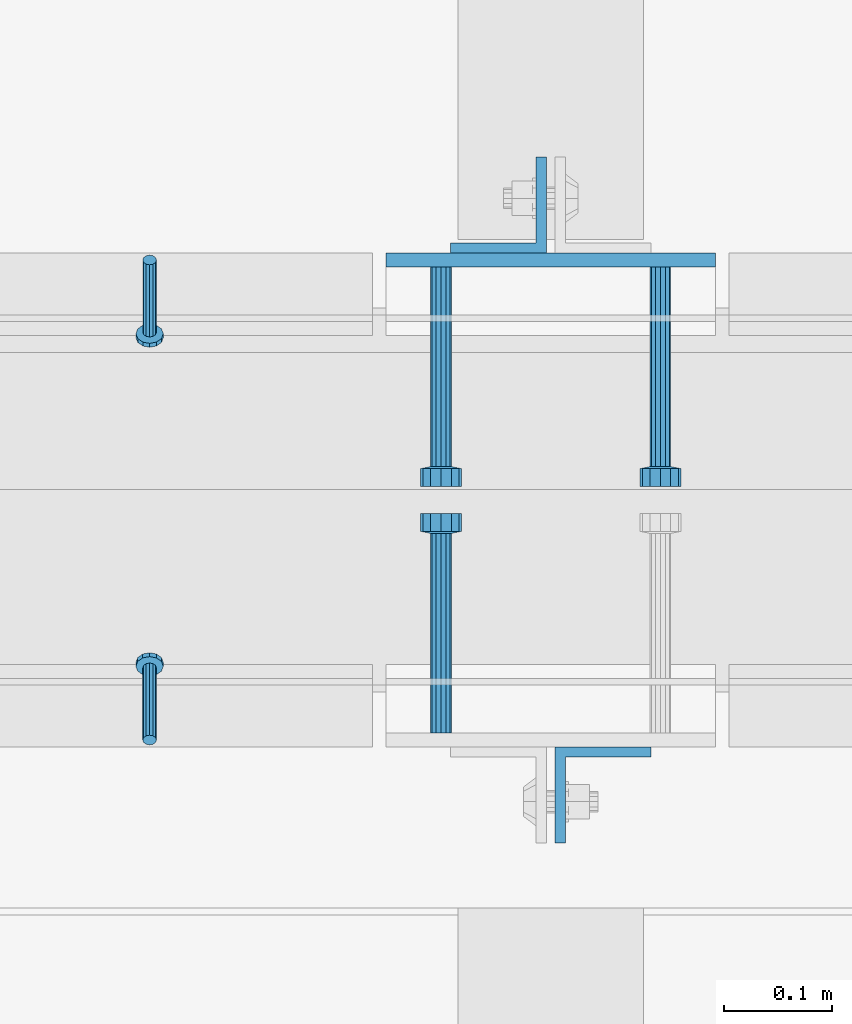
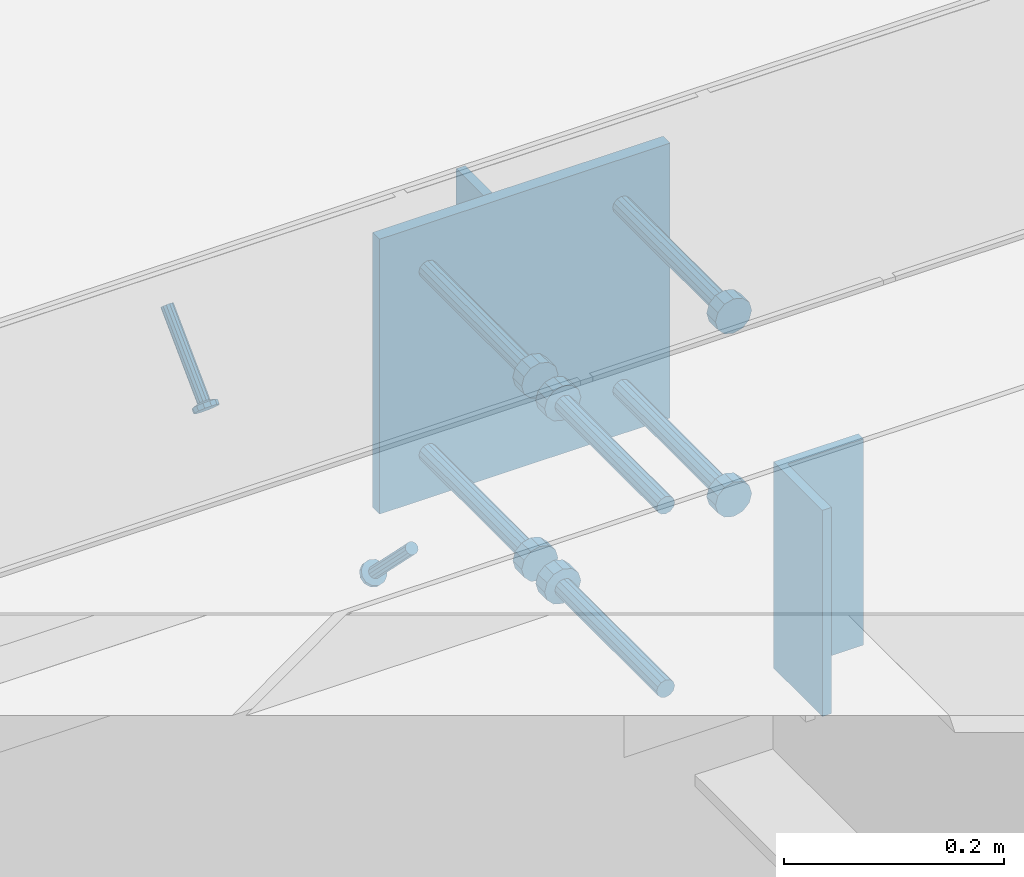
# One storey, part 2064 of 3843: 9 beams, 2 members, 6 elements without a shape of their own.
"""IFC2X3 building model written with IfcOpenShell, lengths in millimetres."""

from ifc_helpers import new_model, si_unit, frame, origin_with_axes, place, context, subcontext, project, spatial, faceted_brep, material, type_object, element, aggregate, save


model = new_model("IFC2X3")

# Units and contexts
model_context = context("Model", 3, precision=1e-05, world=origin_with_axes())
body_context = subcontext(model_context, "Body", "Model", "MODEL_VIEW")
ifc_project = project(units=[si_unit("LENGTHUNIT", "METRE", prefix="MILLI"), si_unit("AREAUNIT", "SQUARE_METRE"), si_unit("VOLUMEUNIT", "CUBIC_METRE"), si_unit("MASSUNIT", "GRAM", prefix="KILO"), si_unit("TIMEUNIT", "SECOND"), si_unit("PLANEANGLEUNIT", "RADIAN"), si_unit("SOLIDANGLEUNIT", "STERADIAN"), si_unit("THERMODYNAMICTEMPERATUREUNIT", "DEGREE_CELSIUS"), si_unit("LUMINOUSINTENSITYUNIT", "LUMEN")], contexts=[model_context])

# Site, building, storey
site_placement = place(None, origin_with_axes())
site = spatial("IfcSite", under=ifc_project, at=site_placement, CompositionType="ELEMENT")
building_placement = place(site_placement, origin_with_axes())
building = spatial("IfcBuilding", under=site, at=building_placement, Name="Undefined", CompositionType="ELEMENT")
storey_placement = place(building_placement, origin_with_axes())
storey = spatial("IfcBuildingStorey", under=building, at=storey_placement, Name="Undefined", CompositionType="ELEMENT", Elevation=0.0)

# Assembly, member
assembly_1_placement = place(storey_placement, origin_with_axes())
assembly_1 = element("IfcElementAssembly", 1, at=assembly_1_placement, inside=storey, Name="ANGLE", AssemblyPlace="NOTDEFINED", PredefinedType="RIGID_FRAME")
ifc_material_1 = material(Name="STEEL/A108")
member_type = type_object("IfcMemberType", PredefinedType="NOTDEFINED")
member_1_placement = place(assembly_1_placement, frame((47809.1772929978, 20456.5250055596, 30397.4500030518), z_axis=(1.0, 0.0, 0.0), x_axis=(0.0, -0.707106781186548, -0.707106781186548)))
member_1 = element("IfcMember", 2, at=member_1_placement, type_object=member_type, material=ifc_material_1, Name="HEADED STUD ANCHOR", context=body_context, shape_type="Brep", body=[
    faceted_brep([(7.27595761418343e-12, -3.18000006675175, 5.5), (0.0, -5.49999999998363, 3.1800000667572), (94.4879985803855, -5.50000000011278, 3.1800000667572), (94.4879985803782, -3.18000006687362, 5.5), (0.0, -6.3499999046162, 0.0), (94.4879985803855, -6.34999990474535, 0.0), (0.0, -5.49999999998363, -3.1800000667572), (94.4879985803855, -5.50000000011278, -3.1800000667572), (7.27595761418343e-12, -3.18000006675175, -5.5), (94.4879985803782, -3.18000006687362, -5.5), (7.27595761418343e-12, -1.81898940354586e-12, -6.34999990463257), (94.4879985803782, -1.20053300634027e-10, -6.34999990463257), (0.0, 3.18000006675175, -5.5), (94.4879985803709, 3.18000006663351, -5.5), (7.27595761418343e-12, 5.49999999998363, -3.1800000667572), (94.4879985803709, 5.49999999987267, -3.1800000667572), (7.27595761418343e-12, 6.3499999046162, 0.0), (94.4879985803673, 6.34999990450706, 0.0), (7.27595761418343e-12, 5.49999999998363, 3.1800000667572), (94.4879985803709, 5.49999999987267, 3.1800000667572), (0.0, 3.18000006675175, 5.5), (94.4879985803709, 3.18000006663351, 5.5), (7.27595761418343e-12, -1.81898940354586e-12, 6.34999990463257), (94.4879985803782, -1.20053300634027e-10, 6.34999990463257), (96.5199985498621, -10.9899997712273, 6.34999990463257), (96.5199985498548, -6.34000015270249, 10.9899997711182), (96.5199985498621, -12.6999998093743, 0.0), (96.5199985498621, -10.9899997712273, -6.34999990463257), (96.5199985498548, -6.34000015270249, -10.9899997711182), (96.5199985498475, -1.21872290037572e-10, -12.6899995803833), (96.5199985498402, 6.34000015245874, -10.9899997711182), (96.519998549833, 10.9899997709817, -6.34999990463257), (96.519998549833, 12.6999998091305, 0.0), (96.519998549833, 10.9899997709817, 6.34999990463257), (96.5199985498402, 6.34000015245874, 10.9899997711182), (96.5199985498475, -1.21872290037572e-10, 12.6899995803833), (101.599998473539, -10.9899997712328, 6.34999990463257), (101.599998473532, -6.34000015270976, 10.9899997711182), (101.599998473539, -12.6999998093797, 0.0), (101.599998473539, -10.9899997712328, -6.34999990463257), (101.599998473532, -6.34000015270976, -10.9899997711182), (101.599998473524, -1.29148247651756e-10, -12.6899995803833), (101.599998473517, 6.34000015245329, -10.9899997711182), (101.59999847351, 10.9899997709763, -6.34999990463257), (101.599998473503, 12.6999998091196, 0.0), (101.59999847351, 10.9899997709763, 6.34999990463257), (101.599998473517, 6.34000015245329, 10.9899997711182), (101.599998473524, -1.29148247651756e-10, 12.6899995803833)], [[[0, 1, 2, 3]], [[1, 4, 5, 2]], [[4, 6, 7, 5]], [[6, 8, 9, 7]], [[8, 10, 11, 9]], [[10, 12, 13, 11]], [[12, 14, 15, 13]], [[14, 16, 17, 15]], [[16, 18, 19, 17]], [[18, 20, 21, 19]], [[20, 22, 23, 21]], [[22, 0, 3, 23]], [[22, 20, 18, 16, 14, 12, 10, 8, 6, 4, 1, 0]], [[3, 2, 24, 25]], [[2, 5, 26, 24]], [[5, 7, 27, 26]], [[7, 9, 28, 27]], [[9, 11, 29, 28]], [[11, 13, 30, 29]], [[13, 15, 31, 30]], [[15, 17, 32, 31]], [[17, 19, 33, 32]], [[19, 21, 34, 33]], [[21, 23, 35, 34]], [[23, 3, 25, 35]], [[25, 24, 36, 37]], [[24, 26, 38, 36]], [[26, 27, 39, 38]], [[27, 28, 40, 39]], [[28, 29, 41, 40]], [[29, 30, 42, 41]], [[30, 31, 43, 42]], [[31, 32, 44, 43]], [[32, 33, 45, 44]], [[33, 34, 46, 45]], [[34, 35, 47, 46]], [[35, 25, 37, 47]], [[38, 39, 40, 41, 42, 43, 44, 45, 46, 47, 37, 36]]]),
])
aggregate(assembly_1, [member_1])

assembly_2_placement = place(storey_placement, origin_with_axes())
assembly_2 = element("IfcElementAssembly", 3, at=assembly_2_placement, inside=storey, Name="ANGLE", AssemblyPlace="NOTDEFINED", PredefinedType="RIGID_FRAME")
member_2_placement = place(assembly_2_placement, frame((47809.1402526855, 20012.0249972574, 30397.4500030518), z_axis=(-1.0, 0.0, 0.0), x_axis=(5.70000238222118e-08, 0.707106781186546, -0.707106781186546)))
member_2 = element("IfcMember", 4, at=member_2_placement, type_object=member_type, material=ifc_material_1, Name="HEADED STUD ANCHOR", context=body_context, shape_type="Brep", body=[
    faceted_brep([(7.27595761418343e-12, -3.18000006675175, 5.5), (0.0, -5.49999999998363, 3.1800000667572), (94.4879985803855, -5.50000000011278, 3.1800000667572), (94.4879985803782, -3.18000006687362, 5.5), (0.0, -6.3499999046162, 0.0), (94.4879985803855, -6.34999990474535, 0.0), (0.0, -5.49999999998363, -3.1800000667572), (94.4879985803855, -5.50000000011278, -3.1800000667572), (7.27595761418343e-12, -3.18000006675175, -5.5), (94.4879985803782, -3.18000006687362, -5.5), (7.27595761418343e-12, -1.81898940354586e-12, -6.34999990463257), (94.4879985803782, -1.20053300634027e-10, -6.34999990463257), (0.0, 3.18000006675175, -5.5), (94.4879985803709, 3.18000006663351, -5.5), (7.27595761418343e-12, 5.49999999998363, -3.1800000667572), (94.4879985803709, 5.49999999987267, -3.1800000667572), (7.27595761418343e-12, 6.3499999046162, 0.0), (94.4879985803673, 6.34999990450706, 0.0), (7.27595761418343e-12, 5.49999999998363, 3.1800000667572), (94.4879985803709, 5.49999999987267, 3.1800000667572), (0.0, 3.18000006675175, 5.5), (94.4879985803709, 3.18000006663351, 5.5), (7.27595761418343e-12, -1.81898940354586e-12, 6.34999990463257), (94.4879985803782, -1.20053300634027e-10, 6.34999990463257), (96.5199985498621, -10.9899997712273, 6.34999990463257), (96.5199985498548, -6.34000015270249, 10.9899997711182), (96.5199985498621, -12.6999998093743, 0.0), (96.5199985498621, -10.9899997712273, -6.34999990463257), (96.5199985498548, -6.34000015270249, -10.9899997711182), (96.5199985498475, -1.21872290037572e-10, -12.6899995803833), (96.5199985498402, 6.34000015245874, -10.9899997711182), (96.519998549833, 10.9899997709817, -6.34999990463257), (96.519998549833, 12.6999998091305, 0.0), (96.519998549833, 10.9899997709817, 6.34999990463257), (96.5199985498402, 6.34000015245874, 10.9899997711182), (96.5199985498475, -1.21872290037572e-10, 12.6899995803833), (101.599998473539, -10.9899997712328, 6.34999990463257), (101.599998473532, -6.34000015270976, 10.9899997711182), (101.599998473539, -12.6999998093797, 0.0), (101.599998473539, -10.9899997712328, -6.34999990463257), (101.599998473532, -6.34000015270976, -10.9899997711182), (101.599998473524, -1.29148247651756e-10, -12.6899995803833), (101.599998473517, 6.34000015245329, -10.9899997711182), (101.59999847351, 10.9899997709763, -6.34999990463257), (101.599998473503, 12.6999998091196, 0.0), (101.59999847351, 10.9899997709763, 6.34999990463257), (101.599998473517, 6.34000015245329, 10.9899997711182), (101.599998473524, -1.29148247651756e-10, 12.6899995803833)], [[[0, 1, 2, 3]], [[1, 4, 5, 2]], [[4, 6, 7, 5]], [[6, 8, 9, 7]], [[8, 10, 11, 9]], [[10, 12, 13, 11]], [[12, 14, 15, 13]], [[14, 16, 17, 15]], [[16, 18, 19, 17]], [[18, 20, 21, 19]], [[20, 22, 23, 21]], [[22, 0, 3, 23]], [[22, 20, 18, 16, 14, 12, 10, 8, 6, 4, 1, 0]], [[3, 2, 24, 25]], [[2, 5, 26, 24]], [[5, 7, 27, 26]], [[7, 9, 28, 27]], [[9, 11, 29, 28]], [[11, 13, 30, 29]], [[13, 15, 31, 30]], [[15, 17, 32, 31]], [[17, 19, 33, 32]], [[19, 21, 34, 33]], [[21, 23, 35, 34]], [[23, 3, 25, 35]], [[25, 24, 36, 37]], [[24, 26, 38, 36]], [[26, 27, 39, 38]], [[27, 28, 40, 39]], [[28, 29, 41, 40]], [[29, 30, 42, 41]], [[30, 31, 43, 42]], [[31, 32, 44, 43]], [[32, 33, 45, 44]], [[33, 34, 46, 45]], [[34, 35, 47, 46]], [[35, 25, 37, 47]], [[38, 39, 40, 41, 42, 43, 44, 45, 46, 47, 37, 36]]]),
])
aggregate(assembly_2, [member_2])

# Assembly, beam
assembly_3_placement = place(storey_placement, origin_with_axes())
assembly_3 = element("IfcElementAssembly", 5, at=assembly_3_placement, inside=storey, Name="EMBED PLATE", AssemblyPlace="NOTDEFINED", PredefinedType="RIGID_FRAME")
ifc_material_2 = material(Name="STEEL/A36")
beam_type_1 = type_object("IfcBeamType", PredefinedType="NOTDEFINED")
beam_1_placement = place(assembly_3_placement, frame((48180.625, 20456.5250030518, 30397.45), z_axis=(-1.0, 0.0, 0.0), x_axis=(0.0, 0.0, -1.0)))
beam_1 = element("IfcBeam", 6, at=beam_1_placement, type_object=beam_type_1, material=ifc_material_2, Name="EMBED PLATE", context=body_context, shape_type="Brep", body=[
    faceted_brep([(-1.0550138540566e-10, 6.34999999999854, -152.400000000664), (1.0550138540566e-10, 6.34999999999854, 152.400000000656), (304.799999999999, 6.34999999999854, 152.400000000001), (304.799999999999, 6.34999999999854, -152.400000000001), (1.0550138540566e-10, -6.34999999999854, 152.400000000656), (304.799999999999, -6.34999999999854, 152.400000000001), (-1.0550138540566e-10, -6.34999999999854, -152.400000000664), (304.799999999999, -6.34999999999854, -152.400000000001)], [[[0, 1, 2, 3]], [[1, 4, 5, 2]], [[4, 6, 7, 5]], [[6, 0, 3, 7]], [[5, 7, 3, 2]], [[6, 4, 1, 0]]]),
])

assembly_4_placement = place(storey_placement, origin_with_axes())
assembly_4 = element("IfcElementAssembly", 7, at=assembly_4_placement, inside=storey, Name="BEAM", AssemblyPlace="NOTDEFINED", PredefinedType="RIGID_FRAME")
beam_type_2 = type_object("IfcBeamType", Name="L3-1/2X3-1/2X3/8", PredefinedType="NOTDEFINED")
beam_2_placement = place(assembly_4_placement, frame((48132.20625, 20507.3250030517, 30365.7), z_axis=(-1.0, 0.0, 0.0), x_axis=(0.0, 0.0, -1.0)))
beam_2 = element("IfcBeam", 8, at=beam_2_placement, type_object=beam_type_2, material=ifc_material_2, Name="ANGLE", ObjectType="L3-1/2X3-1/2X3/8", context=body_context, shape_type="Brep", body=[
    faceted_brep([(-3.63797880709171e-12, 44.4499999999971, -44.4500000000007), (-3.63797880709171e-12, 44.4499999999971, 44.4500000000007), (228.600000000006, 44.4499999999971, 44.4500000000007), (228.600000000006, 44.4499999999971, -44.4500000000007), (0.0, 34.9250000000029, 44.4500000000007), (228.600000000006, 34.9250000000029, 44.4500000000007), (0.0, 34.9250000000029, -34.9250000000029), (228.600000000006, 34.9250000000029, -34.9249999999993), (0.0, -44.4499999999971, -34.9249999999993), (228.600000000006, -44.4499999999971, -34.9249999999993), (3.63797880709171e-12, -44.4499999999971, -44.4500000000007), (228.600000000006, -44.4499999999971, -44.4500000000007)], [[[0, 1, 2, 3]], [[1, 4, 5, 2]], [[4, 6, 7, 5]], [[6, 8, 9, 7]], [[8, 10, 11, 9]], [[10, 0, 3, 11]], [[5, 7, 9, 11, 3, 2]], [[10, 8, 6, 4, 1, 0]]]),
])
aggregate(assembly_4, [beam_2])

assembly_5_placement = place(storey_placement, origin_with_axes())
assembly_5 = element("IfcElementAssembly", 9, at=assembly_5_placement, inside=storey, Name="BEAM", AssemblyPlace="NOTDEFINED", PredefinedType="RIGID_FRAME")
beam_3_placement = place(assembly_5_placement, frame((48229.04375, 19961.2249969482, 30365.7), z_axis=(1.0, 0.0, 0.0), x_axis=(0.0, 0.0, -1.0)))
beam_3 = element("IfcBeam", 10, at=beam_3_placement, type_object=beam_type_2, material=ifc_material_2, Name="ANGLE", ObjectType="L3-1/2X3-1/2X3/8", context=body_context, shape_type="Brep", body=[
    faceted_brep([(-3.63797880709171e-12, 44.4499999999971, -44.4500000000007), (-3.63797880709171e-12, 44.4499999999971, 44.4500000000007), (228.600000000006, 44.4499999999971, 44.4500000000007), (228.600000000006, 44.4499999999971, -44.4500000000007), (0.0, 34.9250000000029, 44.4500000000007), (228.600000000006, 34.9250000000029, 44.4500000000007), (0.0, 34.9250000000029, -34.9250000000029), (228.600000000006, 34.9250000000029, -34.9249999999993), (0.0, -44.4499999999971, -34.9249999999993), (228.600000000006, -44.4499999999971, -34.9249999999993), (3.63797880709171e-12, -44.4499999999971, -44.4500000000007), (228.600000000006, -44.4499999999971, -44.4500000000007)], [[[0, 1, 2, 3]], [[1, 4, 5, 2]], [[4, 6, 7, 5]], [[6, 8, 9, 7]], [[8, 10, 11, 9]], [[10, 0, 3, 11]], [[5, 7, 9, 11, 3, 2]], [[10, 8, 6, 4, 1, 0]]]),
])
aggregate(assembly_5, [beam_3])

# Beam
beam_type_3 = type_object("IfcBeamType", PredefinedType="NOTDEFINED")
beam_4_placement = place(assembly_3_placement, frame((48282.225, 20450.1750030518, 30346.65), z_axis=(1.0, 0.0, 0.0), x_axis=(0.0, -1.0, 0.0)))
beam_4 = element("IfcBeam", 11, at=beam_4_placement, type_object=beam_type_3, material=ifc_material_1, Name="HEADED STUD ANCHOR", context=body_context, shape_type="Brep", body=[
    faceted_brep([(0.0, -9.52000045776367, 0.0), (0.0, -8.25, -4.76000022888184), (184.912000000004, -8.25, -4.76000022888184), (184.912000000004, -9.52000045776367, 0.0), (0.0, -4.76000022888184, -8.25), (184.912000000004, -4.76000022888184, -8.25), (0.0, 0.0, -9.52000045776367), (184.912000000004, 0.0, -9.52000045776367), (0.0, 4.76000022888184, -8.25), (184.912000000004, 4.76000022888184, -8.25), (0.0, 8.25, -4.76000022888184), (184.912000000004, 8.25, -4.76000022888184), (0.0, 9.52000045776367, 0.0), (184.912000000004, 9.52000045776367, 0.0), (0.0, 8.25, 4.76000022888184), (184.912000000004, 8.25, 4.76000022888184), (0.0, 4.76000022888184, 8.25), (184.912000000004, 4.76000022888184, 8.25), (0.0, 0.0, 9.52000045776367), (184.912000000004, 0.0, 9.52000045776367), (0.0, -4.76000022888184, 8.25), (184.912000000004, -4.76000022888184, 8.25), (0.0, -8.25, 4.76000022888184), (184.912000000004, -8.25, 4.76000022888184), (186.944000000003, -16.5, -9.52000045776367), (186.944000000003, -19.0499992370605, 0.0), (186.944000000003, -9.52000045776367, -16.5), (186.944000000003, 0.0, -19.0499992370605), (186.944000000003, 9.52000045776367, -16.5), (186.944000000003, 16.5, -9.52000045776367), (186.944000000003, 19.0499992370605, 0.0), (186.944000000003, 16.5, 9.52000045776367), (186.944000000003, 9.52000045776367, 16.5), (186.944000000003, 0.0, 19.0499992370605), (186.944000000003, -9.52000045776367, 16.5), (186.944000000003, -16.5, 9.52000045776367), (203.199999999997, -16.5, -9.52000045776367), (203.199999999997, -19.0499992370605, 0.0), (203.199999999997, -9.52000045776367, -16.5), (203.199999999997, 0.0, -19.0499992370605), (203.199999999997, 9.52000045776367, -16.5), (203.199999999997, 16.5, -9.52000045776367), (203.199999999997, 19.0499992370605, 0.0), (203.199999999997, 16.5, 9.52000045776367), (203.199999999997, 9.52000045776367, 16.5), (203.199999999997, 0.0, 19.0499992370605), (203.199999999997, -9.52000045776367, 16.5), (203.199999999997, -16.5, 9.52000045776367)], [[[0, 1, 2, 3]], [[1, 4, 5, 2]], [[4, 6, 7, 5]], [[6, 8, 9, 7]], [[8, 10, 11, 9]], [[10, 12, 13, 11]], [[12, 14, 15, 13]], [[14, 16, 17, 15]], [[16, 18, 19, 17]], [[18, 20, 21, 19]], [[20, 22, 23, 21]], [[22, 0, 3, 23]], [[22, 20, 18, 16, 14, 12, 10, 8, 6, 4, 1, 0]], [[3, 2, 24, 25]], [[2, 5, 26, 24]], [[5, 7, 27, 26]], [[7, 9, 28, 27]], [[9, 11, 29, 28]], [[11, 13, 30, 29]], [[13, 15, 31, 30]], [[15, 17, 32, 31]], [[17, 19, 33, 32]], [[19, 21, 34, 33]], [[21, 23, 35, 34]], [[23, 3, 25, 35]], [[25, 24, 36, 37]], [[24, 26, 38, 36]], [[26, 27, 39, 38]], [[27, 28, 40, 39]], [[28, 29, 41, 40]], [[29, 30, 42, 41]], [[30, 31, 43, 42]], [[31, 32, 44, 43]], [[32, 33, 45, 44]], [[33, 34, 46, 45]], [[34, 35, 47, 46]], [[35, 25, 37, 47]], [[38, 39, 40, 41, 42, 43, 44, 45, 46, 47, 37, 36]]]),
])

beam_5_placement = place(assembly_3_placement, frame((48282.225, 20450.1750030518, 30143.45), z_axis=(1.0, 0.0, 0.0), x_axis=(0.0, -1.0, 0.0)))
beam_5 = element("IfcBeam", 12, at=beam_5_placement, type_object=beam_type_3, material=ifc_material_1, Name="HEADED STUD ANCHOR", context=body_context, shape_type="Brep", body=[
    faceted_brep([(0.0, -9.52000045776367, 0.0), (0.0, -8.25, -4.76000022888184), (184.912000000004, -8.25, -4.76000022888184), (184.912000000004, -9.52000045776367, 0.0), (0.0, -4.76000022888184, -8.25), (184.912000000004, -4.76000022888184, -8.25), (0.0, 0.0, -9.52000045776367), (184.912000000004, 0.0, -9.52000045776367), (0.0, 4.76000022888184, -8.25), (184.912000000004, 4.76000022888184, -8.25), (0.0, 8.25, -4.76000022888184), (184.912000000004, 8.25, -4.76000022888184), (0.0, 9.52000045776367, 0.0), (184.912000000004, 9.52000045776367, 0.0), (0.0, 8.25, 4.76000022888184), (184.912000000004, 8.25, 4.76000022888184), (0.0, 4.76000022888184, 8.25), (184.912000000004, 4.76000022888184, 8.25), (0.0, 0.0, 9.52000045776367), (184.912000000004, 0.0, 9.52000045776367), (0.0, -4.76000022888184, 8.25), (184.912000000004, -4.76000022888184, 8.25), (0.0, -8.25, 4.76000022888184), (184.912000000004, -8.25, 4.76000022888184), (186.944000000003, -16.5, -9.52000045776367), (186.944000000003, -19.0499992370605, 0.0), (186.944000000003, -9.52000045776367, -16.5), (186.944000000003, 0.0, -19.0499992370605), (186.944000000003, 9.52000045776367, -16.5), (186.944000000003, 16.5, -9.52000045776367), (186.944000000003, 19.0499992370605, 0.0), (186.944000000003, 16.5, 9.52000045776367), (186.944000000003, 9.52000045776367, 16.5), (186.944000000003, 0.0, 19.0499992370605), (186.944000000003, -9.52000045776367, 16.5), (186.944000000003, -16.5, 9.52000045776367), (203.199999999997, -16.5, -9.52000045776367), (203.199999999997, -19.0499992370605, 0.0), (203.199999999997, -9.52000045776367, -16.5), (203.199999999997, 0.0, -19.0499992370605), (203.199999999997, 9.52000045776367, -16.5), (203.199999999997, 16.5, -9.52000045776367), (203.199999999997, 19.0499992370605, 0.0), (203.199999999997, 16.5, 9.52000045776367), (203.199999999997, 9.52000045776367, 16.5), (203.199999999997, 0.0, 19.0499992370605), (203.199999999997, -9.52000045776367, 16.5), (203.199999999997, -16.5, 9.52000045776367)], [[[0, 1, 2, 3]], [[1, 4, 5, 2]], [[4, 6, 7, 5]], [[6, 8, 9, 7]], [[8, 10, 11, 9]], [[10, 12, 13, 11]], [[12, 14, 15, 13]], [[14, 16, 17, 15]], [[16, 18, 19, 17]], [[18, 20, 21, 19]], [[20, 22, 23, 21]], [[22, 0, 3, 23]], [[22, 20, 18, 16, 14, 12, 10, 8, 6, 4, 1, 0]], [[3, 2, 24, 25]], [[2, 5, 26, 24]], [[5, 7, 27, 26]], [[7, 9, 28, 27]], [[9, 11, 29, 28]], [[11, 13, 30, 29]], [[13, 15, 31, 30]], [[15, 17, 32, 31]], [[17, 19, 33, 32]], [[19, 21, 34, 33]], [[21, 23, 35, 34]], [[23, 3, 25, 35]], [[25, 24, 36, 37]], [[24, 26, 38, 36]], [[26, 27, 39, 38]], [[27, 28, 40, 39]], [[28, 29, 41, 40]], [[29, 30, 42, 41]], [[30, 31, 43, 42]], [[31, 32, 44, 43]], [[32, 33, 45, 44]], [[33, 34, 46, 45]], [[34, 35, 47, 46]], [[35, 25, 37, 47]], [[38, 39, 40, 41, 42, 43, 44, 45, 46, 47, 37, 36]]]),
])

beam_6_placement = place(assembly_3_placement, frame((48079.025, 20450.1750030518, 30346.65), z_axis=(1.0, 0.0, 0.0), x_axis=(0.0, -1.0, 0.0)))
beam_6 = element("IfcBeam", 13, at=beam_6_placement, type_object=beam_type_3, material=ifc_material_2, Name="PLATE", context=body_context, shape_type="Brep", body=[
    faceted_brep([(0.0, -9.52000045776367, 0.0), (0.0, -8.25, -4.76000022888184), (184.912000000004, -8.25, -4.76000022888184), (184.912000000004, -9.52000045776367, 0.0), (0.0, -4.76000022888184, -8.25), (184.912000000004, -4.76000022888184, -8.25), (0.0, 0.0, -9.52000045776367), (184.912000000004, 0.0, -9.52000045776367), (0.0, 4.76000022888184, -8.25), (184.912000000004, 4.76000022888184, -8.25), (0.0, 8.25, -4.76000022888184), (184.912000000004, 8.25, -4.76000022888184), (0.0, 9.52000045776367, 0.0), (184.912000000004, 9.52000045776367, 0.0), (0.0, 8.25, 4.76000022888184), (184.912000000004, 8.25, 4.76000022888184), (0.0, 4.76000022888184, 8.25), (184.912000000004, 4.76000022888184, 8.25), (0.0, 0.0, 9.52000045776367), (184.912000000004, 0.0, 9.52000045776367), (0.0, -4.76000022888184, 8.25), (184.912000000004, -4.76000022888184, 8.25), (0.0, -8.25, 4.76000022888184), (184.912000000004, -8.25, 4.76000022888184), (186.944000000003, -16.5, -9.52000045776367), (186.944000000003, -19.0499992370605, 0.0), (186.944000000003, -9.52000045776367, -16.5), (186.944000000003, 0.0, -19.0499992370605), (186.944000000003, 9.52000045776367, -16.5), (186.944000000003, 16.5, -9.52000045776367), (186.944000000003, 19.0499992370605, 0.0), (186.944000000003, 16.5, 9.52000045776367), (186.944000000003, 9.52000045776367, 16.5), (186.944000000003, 0.0, 19.0499992370605), (186.944000000003, -9.52000045776367, 16.5), (186.944000000003, -16.5, 9.52000045776367), (203.199999999997, -16.5, -9.52000045776367), (203.199999999997, -19.0499992370605, 0.0), (203.199999999997, -9.52000045776367, -16.5), (203.199999999997, 0.0, -19.0499992370605), (203.199999999997, 9.52000045776367, -16.5), (203.199999999997, 16.5, -9.52000045776367), (203.199999999997, 19.0499992370605, 0.0), (203.199999999997, 16.5, 9.52000045776367), (203.199999999997, 9.52000045776367, 16.5), (203.199999999997, 0.0, 19.0499992370605), (203.199999999997, -9.52000045776367, 16.5), (203.199999999997, -16.5, 9.52000045776367)], [[[0, 1, 2, 3]], [[1, 4, 5, 2]], [[4, 6, 7, 5]], [[6, 8, 9, 7]], [[8, 10, 11, 9]], [[10, 12, 13, 11]], [[12, 14, 15, 13]], [[14, 16, 17, 15]], [[16, 18, 19, 17]], [[18, 20, 21, 19]], [[20, 22, 23, 21]], [[22, 0, 3, 23]], [[22, 20, 18, 16, 14, 12, 10, 8, 6, 4, 1, 0]], [[3, 2, 24, 25]], [[2, 5, 26, 24]], [[5, 7, 27, 26]], [[7, 9, 28, 27]], [[9, 11, 29, 28]], [[11, 13, 30, 29]], [[13, 15, 31, 30]], [[15, 17, 32, 31]], [[17, 19, 33, 32]], [[19, 21, 34, 33]], [[21, 23, 35, 34]], [[23, 3, 25, 35]], [[25, 24, 36, 37]], [[24, 26, 38, 36]], [[26, 27, 39, 38]], [[27, 28, 40, 39]], [[28, 29, 41, 40]], [[29, 30, 42, 41]], [[30, 31, 43, 42]], [[31, 32, 44, 43]], [[32, 33, 45, 44]], [[33, 34, 46, 45]], [[34, 35, 47, 46]], [[35, 25, 37, 47]], [[38, 39, 40, 41, 42, 43, 44, 45, 46, 47, 37, 36]]]),
])

beam_7_placement = place(assembly_3_placement, frame((48079.025, 20450.1750030518, 30143.45), z_axis=(1.0, 0.0, 0.0), x_axis=(0.0, -1.0, 0.0)))
beam_7 = element("IfcBeam", 14, at=beam_7_placement, type_object=beam_type_3, material=ifc_material_1, Name="HEADED STUD ANCHOR", context=body_context, shape_type="Brep", body=[
    faceted_brep([(0.0, -9.52000045776367, 0.0), (0.0, -8.25, -4.76000022888184), (184.912000000004, -8.25, -4.76000022888184), (184.912000000004, -9.52000045776367, 0.0), (0.0, -4.76000022888184, -8.25), (184.912000000004, -4.76000022888184, -8.25), (0.0, 0.0, -9.52000045776367), (184.912000000004, 0.0, -9.52000045776367), (0.0, 4.76000022888184, -8.25), (184.912000000004, 4.76000022888184, -8.25), (0.0, 8.25, -4.76000022888184), (184.912000000004, 8.25, -4.76000022888184), (0.0, 9.52000045776367, 0.0), (184.912000000004, 9.52000045776367, 0.0), (0.0, 8.25, 4.76000022888184), (184.912000000004, 8.25, 4.76000022888184), (0.0, 4.76000022888184, 8.25), (184.912000000004, 4.76000022888184, 8.25), (0.0, 0.0, 9.52000045776367), (184.912000000004, 0.0, 9.52000045776367), (0.0, -4.76000022888184, 8.25), (184.912000000004, -4.76000022888184, 8.25), (0.0, -8.25, 4.76000022888184), (184.912000000004, -8.25, 4.76000022888184), (186.944000000003, -16.5, -9.52000045776367), (186.944000000003, -19.0499992370605, 0.0), (186.944000000003, -9.52000045776367, -16.5), (186.944000000003, 0.0, -19.0499992370605), (186.944000000003, 9.52000045776367, -16.5), (186.944000000003, 16.5, -9.52000045776367), (186.944000000003, 19.0499992370605, 0.0), (186.944000000003, 16.5, 9.52000045776367), (186.944000000003, 9.52000045776367, 16.5), (186.944000000003, 0.0, 19.0499992370605), (186.944000000003, -9.52000045776367, 16.5), (186.944000000003, -16.5, 9.52000045776367), (203.199999999997, -16.5, -9.52000045776367), (203.199999999997, -19.0499992370605, 0.0), (203.199999999997, -9.52000045776367, -16.5), (203.199999999997, 0.0, -19.0499992370605), (203.199999999997, 9.52000045776367, -16.5), (203.199999999997, 16.5, -9.52000045776367), (203.199999999997, 19.0499992370605, 0.0), (203.199999999997, 16.5, 9.52000045776367), (203.199999999997, 9.52000045776367, 16.5), (203.199999999997, 0.0, 19.0499992370605), (203.199999999997, -9.52000045776367, 16.5), (203.199999999997, -16.5, 9.52000045776367)], [[[0, 1, 2, 3]], [[1, 4, 5, 2]], [[4, 6, 7, 5]], [[6, 8, 9, 7]], [[8, 10, 11, 9]], [[10, 12, 13, 11]], [[12, 14, 15, 13]], [[14, 16, 17, 15]], [[16, 18, 19, 17]], [[18, 20, 21, 19]], [[20, 22, 23, 21]], [[22, 0, 3, 23]], [[22, 20, 18, 16, 14, 12, 10, 8, 6, 4, 1, 0]], [[3, 2, 24, 25]], [[2, 5, 26, 24]], [[5, 7, 27, 26]], [[7, 9, 28, 27]], [[9, 11, 29, 28]], [[11, 13, 30, 29]], [[13, 15, 31, 30]], [[15, 17, 32, 31]], [[17, 19, 33, 32]], [[19, 21, 34, 33]], [[21, 23, 35, 34]], [[23, 3, 25, 35]], [[25, 24, 36, 37]], [[24, 26, 38, 36]], [[26, 27, 39, 38]], [[27, 28, 40, 39]], [[28, 29, 41, 40]], [[29, 30, 42, 41]], [[30, 31, 43, 42]], [[31, 32, 44, 43]], [[32, 33, 45, 44]], [[33, 34, 46, 45]], [[34, 35, 47, 46]], [[35, 25, 37, 47]], [[38, 39, 40, 41, 42, 43, 44, 45, 46, 47, 37, 36]]]),
])

aggregate(assembly_3, [beam_4, beam_5, beam_6, beam_7, beam_1])

# Assembly, beams
assembly_6_placement = place(storey_placement, origin_with_axes())
assembly_6 = element("IfcElementAssembly", 15, at=assembly_6_placement, inside=storey, Name="EMBED PLATE", AssemblyPlace="NOTDEFINED", PredefinedType="RIGID_FRAME")
beam_8_placement = place(assembly_6_placement, frame((48079.025, 20018.3749969482, 30346.65), z_axis=(-1.0, 0.0, 0.0), x_axis=(0.0, 1.0, 0.0)))
beam_8 = element("IfcBeam", 16, at=beam_8_placement, type_object=beam_type_3, material=ifc_material_1, Name="HEADED STUD ANCHOR", context=body_context, shape_type="Brep", body=[
    faceted_brep([(0.0, -9.52000045776367, 0.0), (0.0, -8.25, -4.76000022888184), (184.912000000004, -8.25, -4.76000022888184), (184.912000000004, -9.52000045776367, 0.0), (0.0, -4.76000022888184, -8.25), (184.912000000004, -4.76000022888184, -8.25), (0.0, 0.0, -9.52000045776367), (184.912000000004, 0.0, -9.52000045776367), (0.0, 4.76000022888184, -8.25), (184.912000000004, 4.76000022888184, -8.25), (0.0, 8.25, -4.76000022888184), (184.912000000004, 8.25, -4.76000022888184), (0.0, 9.52000045776367, 0.0), (184.912000000004, 9.52000045776367, 0.0), (0.0, 8.25, 4.76000022888184), (184.912000000004, 8.25, 4.76000022888184), (0.0, 4.76000022888184, 8.25), (184.912000000004, 4.76000022888184, 8.25), (0.0, 0.0, 9.52000045776367), (184.912000000004, 0.0, 9.52000045776367), (0.0, -4.76000022888184, 8.25), (184.912000000004, -4.76000022888184, 8.25), (0.0, -8.25, 4.76000022888184), (184.912000000004, -8.25, 4.76000022888184), (186.944000000003, -16.5, -9.52000045776367), (186.944000000003, -19.0499992370605, 0.0), (186.944000000003, -9.52000045776367, -16.5), (186.944000000003, 0.0, -19.0499992370605), (186.944000000003, 9.52000045776367, -16.5), (186.944000000003, 16.5, -9.52000045776367), (186.944000000003, 19.0499992370605, 0.0), (186.944000000003, 16.5, 9.52000045776367), (186.944000000003, 9.52000045776367, 16.5), (186.944000000003, 0.0, 19.0499992370605), (186.944000000003, -9.52000045776367, 16.5), (186.944000000003, -16.5, 9.52000045776367), (203.199999999997, -16.5, -9.52000045776367), (203.199999999997, -19.0499992370605, 0.0), (203.199999999997, -9.52000045776367, -16.5), (203.199999999997, 0.0, -19.0499992370605), (203.199999999997, 9.52000045776367, -16.5), (203.199999999997, 16.5, -9.52000045776367), (203.199999999997, 19.0499992370605, 0.0), (203.199999999997, 16.5, 9.52000045776367), (203.199999999997, 9.52000045776367, 16.5), (203.199999999997, 0.0, 19.0499992370605), (203.199999999997, -9.52000045776367, 16.5), (203.199999999997, -16.5, 9.52000045776367)], [[[0, 1, 2, 3]], [[1, 4, 5, 2]], [[4, 6, 7, 5]], [[6, 8, 9, 7]], [[8, 10, 11, 9]], [[10, 12, 13, 11]], [[12, 14, 15, 13]], [[14, 16, 17, 15]], [[16, 18, 19, 17]], [[18, 20, 21, 19]], [[20, 22, 23, 21]], [[22, 0, 3, 23]], [[22, 20, 18, 16, 14, 12, 10, 8, 6, 4, 1, 0]], [[3, 2, 24, 25]], [[2, 5, 26, 24]], [[5, 7, 27, 26]], [[7, 9, 28, 27]], [[9, 11, 29, 28]], [[11, 13, 30, 29]], [[13, 15, 31, 30]], [[15, 17, 32, 31]], [[17, 19, 33, 32]], [[19, 21, 34, 33]], [[21, 23, 35, 34]], [[23, 3, 25, 35]], [[25, 24, 36, 37]], [[24, 26, 38, 36]], [[26, 27, 39, 38]], [[27, 28, 40, 39]], [[28, 29, 41, 40]], [[29, 30, 42, 41]], [[30, 31, 43, 42]], [[31, 32, 44, 43]], [[32, 33, 45, 44]], [[33, 34, 46, 45]], [[34, 35, 47, 46]], [[35, 25, 37, 47]], [[38, 39, 40, 41, 42, 43, 44, 45, 46, 47, 37, 36]]]),
])
beam_9_placement = place(assembly_6_placement, frame((48079.025, 20018.3749969482, 30143.45), z_axis=(-1.0, 0.0, 0.0), x_axis=(0.0, 1.0, 0.0)))
beam_9 = element("IfcBeam", 17, at=beam_9_placement, type_object=beam_type_3, material=ifc_material_1, Name="HEADED STUD ANCHOR", context=body_context, shape_type="Brep", body=[
    faceted_brep([(0.0, -9.52000045776367, 0.0), (0.0, -8.25, -4.76000022888184), (184.912000000004, -8.25, -4.76000022888184), (184.912000000004, -9.52000045776367, 0.0), (0.0, -4.76000022888184, -8.25), (184.912000000004, -4.76000022888184, -8.25), (0.0, 0.0, -9.52000045776367), (184.912000000004, 0.0, -9.52000045776367), (0.0, 4.76000022888184, -8.25), (184.912000000004, 4.76000022888184, -8.25), (0.0, 8.25, -4.76000022888184), (184.912000000004, 8.25, -4.76000022888184), (0.0, 9.52000045776367, 0.0), (184.912000000004, 9.52000045776367, 0.0), (0.0, 8.25, 4.76000022888184), (184.912000000004, 8.25, 4.76000022888184), (0.0, 4.76000022888184, 8.25), (184.912000000004, 4.76000022888184, 8.25), (0.0, 0.0, 9.52000045776367), (184.912000000004, 0.0, 9.52000045776367), (0.0, -4.76000022888184, 8.25), (184.912000000004, -4.76000022888184, 8.25), (0.0, -8.25, 4.76000022888184), (184.912000000004, -8.25, 4.76000022888184), (186.944000000003, -16.5, -9.52000045776367), (186.944000000003, -19.0499992370605, 0.0), (186.944000000003, -9.52000045776367, -16.5), (186.944000000003, 0.0, -19.0499992370605), (186.944000000003, 9.52000045776367, -16.5), (186.944000000003, 16.5, -9.52000045776367), (186.944000000003, 19.0499992370605, 0.0), (186.944000000003, 16.5, 9.52000045776367), (186.944000000003, 9.52000045776367, 16.5), (186.944000000003, 0.0, 19.0499992370605), (186.944000000003, -9.52000045776367, 16.5), (186.944000000003, -16.5, 9.52000045776367), (203.199999999997, -16.5, -9.52000045776367), (203.199999999997, -19.0499992370605, 0.0), (203.199999999997, -9.52000045776367, -16.5), (203.199999999997, 0.0, -19.0499992370605), (203.199999999997, 9.52000045776367, -16.5), (203.199999999997, 16.5, -9.52000045776367), (203.199999999997, 19.0499992370605, 0.0), (203.199999999997, 16.5, 9.52000045776367), (203.199999999997, 9.52000045776367, 16.5), (203.199999999997, 0.0, 19.0499992370605), (203.199999999997, -9.52000045776367, 16.5), (203.199999999997, -16.5, 9.52000045776367)], [[[0, 1, 2, 3]], [[1, 4, 5, 2]], [[4, 6, 7, 5]], [[6, 8, 9, 7]], [[8, 10, 11, 9]], [[10, 12, 13, 11]], [[12, 14, 15, 13]], [[14, 16, 17, 15]], [[16, 18, 19, 17]], [[18, 20, 21, 19]], [[20, 22, 23, 21]], [[22, 0, 3, 23]], [[22, 20, 18, 16, 14, 12, 10, 8, 6, 4, 1, 0]], [[3, 2, 24, 25]], [[2, 5, 26, 24]], [[5, 7, 27, 26]], [[7, 9, 28, 27]], [[9, 11, 29, 28]], [[11, 13, 30, 29]], [[13, 15, 31, 30]], [[15, 17, 32, 31]], [[17, 19, 33, 32]], [[19, 21, 34, 33]], [[21, 23, 35, 34]], [[23, 3, 25, 35]], [[25, 24, 36, 37]], [[24, 26, 38, 36]], [[26, 27, 39, 38]], [[27, 28, 40, 39]], [[28, 29, 41, 40]], [[29, 30, 42, 41]], [[30, 31, 43, 42]], [[31, 32, 44, 43]], [[32, 33, 45, 44]], [[33, 34, 46, 45]], [[34, 35, 47, 46]], [[35, 25, 37, 47]], [[38, 39, 40, 41, 42, 43, 44, 45, 46, 47, 37, 36]]]),
])
aggregate(assembly_6, [beam_8, beam_9])

save(model, "model.ifc")
